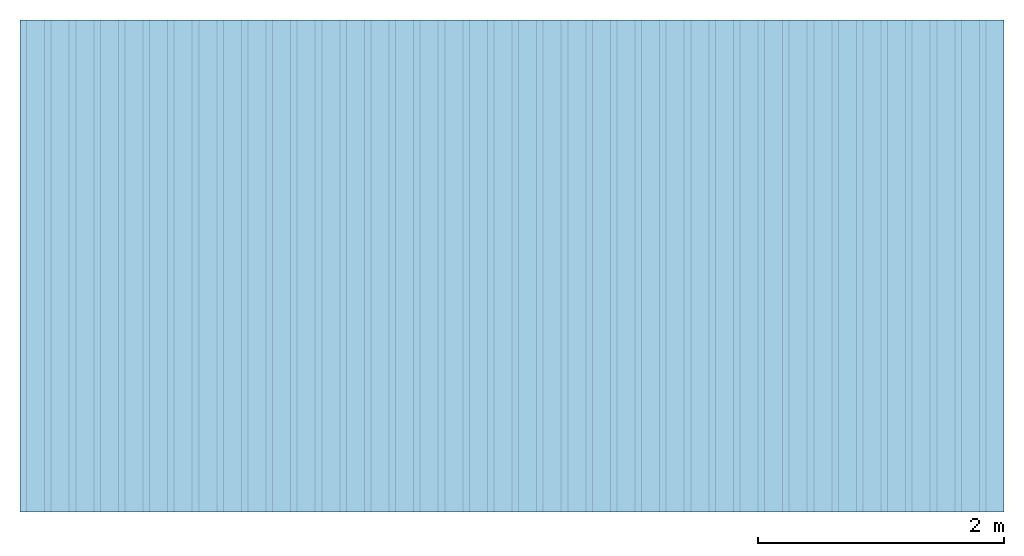
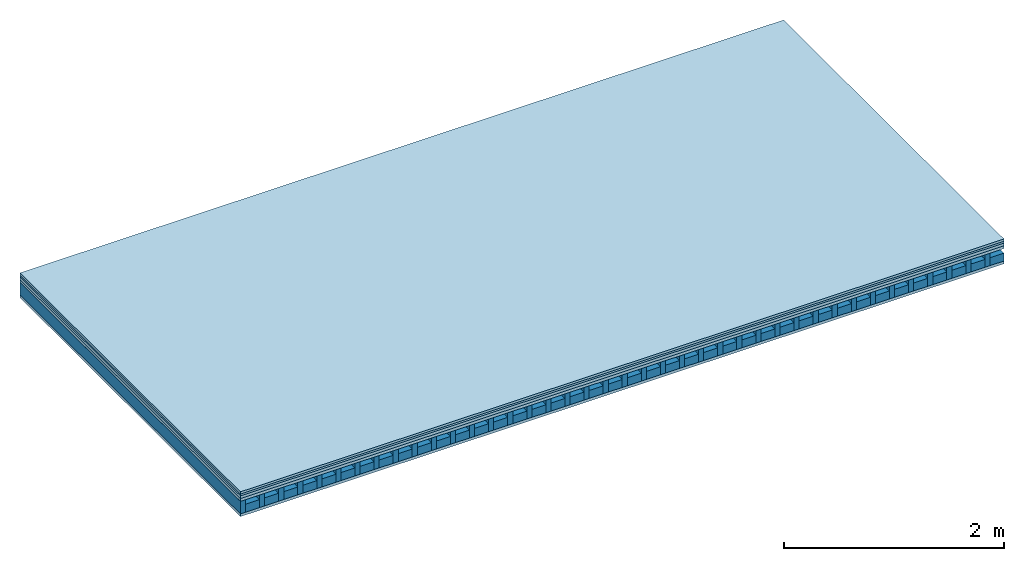
# One storey: 5 plates, 2 members, 1 element without a shape of its own.
"""IFC4 building model written with IfcOpenShell, lengths in metres."""

from ifc_helpers import new_model, si_unit, derived_unit, direction, frame, frame_2d, origin, origin_with_axes, place, context, project, spatial, rectangle, extrude, material, layer, layer_set, type_object, element, aggregate, save


model = new_model("IFC4")

# Units and contexts
plan_context = context("Plan", 3, precision=1e-05, world=origin(), true_north=direction((0.0, 1.0)))
model_context = context("Model", 3, precision=1e-05, world=origin(), true_north=direction((0.0, 1.0)))
ifc_project = project(units=[si_unit("LENGTHUNIT", "METRE"), derived_unit("SOUNDPRESSUREUNIT", [(si_unit("PRESSUREUNIT", "PASCAL", prefix="MICRO"), 0)]), si_unit("ENERGYUNIT", "JOULE", prefix="MEGA"), si_unit("MASSUNIT", "GRAM", prefix="KILO"), derived_unit("THERMALTRANSMITTANCEUNIT", [(si_unit("POWERUNIT", "WATT"), 1), (si_unit("AREAUNIT", "SQUARE_METRE"), -1), (si_unit("THERMODYNAMICTEMPERATUREUNIT", "KELVIN"), -1)]), derived_unit("AREADENSITYUNIT", [(si_unit("MASSUNIT", "GRAM", prefix="KILO"), 1), (si_unit("AREAUNIT", "SQUARE_METRE"), -1)]), derived_unit("USERDEFINED", [(si_unit("ENERGYUNIT", "JOULE", prefix="MEGA"), 1), (si_unit("AREAUNIT", "SQUARE_METRE"), -1)])], contexts=[plan_context, model_context])

# Site, building, storey
site = spatial("IfcSite", under=ifc_project)
building_placement = place(None, origin())
building = spatial("IfcBuilding", under=site, at=building_placement)
storey_placement = place(building_placement, origin())
storey = spatial("IfcBuildingStorey", under=building, at=storey_placement)

# Slab, members, plates
ifc_material_1 = material(Name="Floor heating system Therm38 longitudinal", Category="03.007")
ifc_layer_1 = layer(ifc_material_1, 0.025, Name="On-material")
ifc_material_2 = material(Name="32/30mm", Category="10.009")
ifc_layer_2 = layer(ifc_material_2, 0.02, Name="Impact sound insulation")
ifc_material_3 = material(Category="03.011")
ifc_layer_3 = layer(ifc_material_3, 0.03, Name="on Supporting structure")
ifc_material_4 = material(Name="box-element sheathing above")
ifc_layer_4 = layer(ifc_material_4, 0.031, Name="Sub-floor")
ifc_layer_5 = layer(None, 0.138, Name="Supporting structure")
ifc_material_5 = material(Name="box-element sheathing below")
ifc_layer_6 = layer(ifc_material_5, 0.031, Name="Lower layer 1")
ifc_layer_set = layer_set([ifc_layer_1, ifc_layer_2, ifc_layer_3, ifc_layer_4, ifc_layer_5, ifc_layer_6])
slab_type = type_object("IfcSlabType", Name="A1464", PredefinedType="NOTDEFINED", material=ifc_layer_set)
slab_placement = place(None, frame((0.0, 0.0, 0.0), z_axis=(0.0, 0.0, -1.0), x_axis=(1.0, 0.0, 0.0)))
slab = element("IfcSlab", 1, at=slab_placement, inside=storey, type_object=slab_type, material=ifc_layer_set, Name="Slab #1")
ifc_material_6 = material(Name="box-element LKE 12")
member_1_placement = place(slab_placement, origin())
member_1 = element("IfcMember", 2, at=member_1_placement, material=ifc_material_6, Name="Supporting structure", context=plan_context, shape_type="SweptSolid", body=[
    extrude(rectangle(XDim=0.054, YDim=0.138, at=frame_2d((0.027, 0.069), x_axis=(1.0, 0.0))), frame((0.0, 4.0, 0.106), z_axis=(0.0, -1.0, 0.0), x_axis=(1.0, 0.0, 0.0)), (0.0, 0.0, 1.0), 4.0),
    extrude(rectangle(XDim=0.054, YDim=0.138, at=frame_2d((0.027, 0.069), x_axis=(1.0, 0.0))), frame((0.2, 4.0, 0.106), z_axis=(0.0, -1.0, 0.0), x_axis=(1.0, 0.0, 0.0)), (0.0, 0.0, 1.0), 4.0),
    extrude(rectangle(XDim=0.054, YDim=0.138, at=frame_2d((0.027, 0.069), x_axis=(1.0, 0.0))), frame((0.4, 4.0, 0.106), z_axis=(0.0, -1.0, 0.0), x_axis=(1.0, 0.0, 0.0)), (0.0, 0.0, 1.0), 4.0),
    extrude(rectangle(XDim=0.054, YDim=0.138, at=frame_2d((0.027, 0.069), x_axis=(1.0, 0.0))), frame((0.6, 4.0, 0.106), z_axis=(0.0, -1.0, 0.0), x_axis=(1.0, 0.0, 0.0)), (0.0, 0.0, 1.0), 4.0),
    extrude(rectangle(XDim=0.054, YDim=0.138, at=frame_2d((0.027, 0.069), x_axis=(1.0, 0.0))), frame((0.8, 4.0, 0.106), z_axis=(0.0, -1.0, 0.0), x_axis=(1.0, 0.0, 0.0)), (0.0, 0.0, 1.0), 4.0),
    extrude(rectangle(XDim=0.054, YDim=0.138, at=frame_2d((0.027, 0.069), x_axis=(1.0, 0.0))), frame((1.0, 4.0, 0.106), z_axis=(0.0, -1.0, 0.0), x_axis=(1.0, 0.0, 0.0)), (0.0, 0.0, 1.0), 4.0),
    extrude(rectangle(XDim=0.054, YDim=0.138, at=frame_2d((0.027, 0.069), x_axis=(1.0, 0.0))), frame((1.2, 4.0, 0.106), z_axis=(0.0, -1.0, 0.0), x_axis=(1.0, 0.0, 0.0)), (0.0, 0.0, 1.0), 4.0),
    extrude(rectangle(XDim=0.054, YDim=0.138, at=frame_2d((0.027, 0.069), x_axis=(1.0, 0.0))), frame((1.4, 4.0, 0.106), z_axis=(0.0, -1.0, 0.0), x_axis=(1.0, 0.0, 0.0)), (0.0, 0.0, 1.0), 4.0),
    extrude(rectangle(XDim=0.054, YDim=0.138, at=frame_2d((0.027, 0.069), x_axis=(1.0, 0.0))), frame((1.6, 4.0, 0.106), z_axis=(0.0, -1.0, 0.0), x_axis=(1.0, 0.0, 0.0)), (0.0, 0.0, 1.0), 4.0),
    extrude(rectangle(XDim=0.054, YDim=0.138, at=frame_2d((0.027, 0.069), x_axis=(1.0, 0.0))), frame((1.8, 4.0, 0.106), z_axis=(0.0, -1.0, 0.0), x_axis=(1.0, 0.0, 0.0)), (0.0, 0.0, 1.0), 4.0),
    extrude(rectangle(XDim=0.054, YDim=0.138, at=frame_2d((0.027, 0.069), x_axis=(1.0, 0.0))), frame((2.0, 4.0, 0.106), z_axis=(0.0, -1.0, 0.0), x_axis=(1.0, 0.0, 0.0)), (0.0, 0.0, 1.0), 4.0),
    extrude(rectangle(XDim=0.054, YDim=0.138, at=frame_2d((0.027, 0.069), x_axis=(1.0, 0.0))), frame((2.2, 4.0, 0.106), z_axis=(0.0, -1.0, 0.0), x_axis=(1.0, 0.0, 0.0)), (0.0, 0.0, 1.0), 4.0),
    extrude(rectangle(XDim=0.054, YDim=0.138, at=frame_2d((0.027, 0.069), x_axis=(1.0, 0.0))), frame((2.4, 4.0, 0.106), z_axis=(0.0, -1.0, 0.0), x_axis=(1.0, 0.0, 0.0)), (0.0, 0.0, 1.0), 4.0),
    extrude(rectangle(XDim=0.054, YDim=0.138, at=frame_2d((0.027, 0.069), x_axis=(1.0, 0.0))), frame((2.6, 4.0, 0.106), z_axis=(0.0, -1.0, 0.0), x_axis=(1.0, 0.0, 0.0)), (0.0, 0.0, 1.0), 4.0),
    extrude(rectangle(XDim=0.054, YDim=0.138, at=frame_2d((0.027, 0.069), x_axis=(1.0, 0.0))), frame((2.8, 4.0, 0.106), z_axis=(0.0, -1.0, 0.0), x_axis=(1.0, 0.0, 0.0)), (0.0, 0.0, 1.0), 4.0),
    extrude(rectangle(XDim=0.054, YDim=0.138, at=frame_2d((0.027, 0.069), x_axis=(1.0, 0.0))), frame((3.0, 4.0, 0.106), z_axis=(0.0, -1.0, 0.0), x_axis=(1.0, 0.0, 0.0)), (0.0, 0.0, 1.0), 4.0),
    extrude(rectangle(XDim=0.054, YDim=0.138, at=frame_2d((0.027, 0.069), x_axis=(1.0, 0.0))), frame((3.2, 4.0, 0.106), z_axis=(0.0, -1.0, 0.0), x_axis=(1.0, 0.0, 0.0)), (0.0, 0.0, 1.0), 4.0),
    extrude(rectangle(XDim=0.054, YDim=0.138, at=frame_2d((0.027, 0.069), x_axis=(1.0, 0.0))), frame((3.4, 4.0, 0.106), z_axis=(0.0, -1.0, 0.0), x_axis=(1.0, 0.0, 0.0)), (0.0, 0.0, 1.0), 4.0),
    extrude(rectangle(XDim=0.054, YDim=0.138, at=frame_2d((0.027, 0.069), x_axis=(1.0, 0.0))), frame((3.6, 4.0, 0.106), z_axis=(0.0, -1.0, 0.0), x_axis=(1.0, 0.0, 0.0)), (0.0, 0.0, 1.0), 4.0),
    extrude(rectangle(XDim=0.054, YDim=0.138, at=frame_2d((0.027, 0.069), x_axis=(1.0, 0.0))), frame((3.8, 4.0, 0.106), z_axis=(0.0, -1.0, 0.0), x_axis=(1.0, 0.0, 0.0)), (0.0, 0.0, 1.0), 4.0),
    extrude(rectangle(XDim=0.054, YDim=0.138, at=frame_2d((0.027, 0.069), x_axis=(1.0, 0.0))), frame((4.0, 4.0, 0.106), z_axis=(0.0, -1.0, 0.0), x_axis=(1.0, 0.0, 0.0)), (0.0, 0.0, 1.0), 4.0),
    extrude(rectangle(XDim=0.054, YDim=0.138, at=frame_2d((0.027, 0.069), x_axis=(1.0, 0.0))), frame((4.2, 4.0, 0.106), z_axis=(0.0, -1.0, 0.0), x_axis=(1.0, 0.0, 0.0)), (0.0, 0.0, 1.0), 4.0),
    extrude(rectangle(XDim=0.054, YDim=0.138, at=frame_2d((0.027, 0.069), x_axis=(1.0, 0.0))), frame((4.4, 4.0, 0.106), z_axis=(0.0, -1.0, 0.0), x_axis=(1.0, 0.0, 0.0)), (0.0, 0.0, 1.0), 4.0),
    extrude(rectangle(XDim=0.054, YDim=0.138, at=frame_2d((0.027, 0.069), x_axis=(1.0, 0.0))), frame((4.6, 4.0, 0.106), z_axis=(0.0, -1.0, 0.0), x_axis=(1.0, 0.0, 0.0)), (0.0, 0.0, 1.0), 4.0),
    extrude(rectangle(XDim=0.054, YDim=0.138, at=frame_2d((0.027, 0.069), x_axis=(1.0, 0.0))), frame((4.8, 4.0, 0.106), z_axis=(0.0, -1.0, 0.0), x_axis=(1.0, 0.0, 0.0)), (0.0, 0.0, 1.0), 4.0),
    extrude(rectangle(XDim=0.054, YDim=0.138, at=frame_2d((0.027, 0.069), x_axis=(1.0, 0.0))), frame((5.0, 4.0, 0.106), z_axis=(0.0, -1.0, 0.0), x_axis=(1.0, 0.0, 0.0)), (0.0, 0.0, 1.0), 4.0),
    extrude(rectangle(XDim=0.054, YDim=0.138, at=frame_2d((0.027, 0.069), x_axis=(1.0, 0.0))), frame((5.2, 4.0, 0.106), z_axis=(0.0, -1.0, 0.0), x_axis=(1.0, 0.0, 0.0)), (0.0, 0.0, 1.0), 4.0),
    extrude(rectangle(XDim=0.054, YDim=0.138, at=frame_2d((0.027, 0.069), x_axis=(1.0, 0.0))), frame((5.4, 4.0, 0.106), z_axis=(0.0, -1.0, 0.0), x_axis=(1.0, 0.0, 0.0)), (0.0, 0.0, 1.0), 4.0),
    extrude(rectangle(XDim=0.054, YDim=0.138, at=frame_2d((0.027, 0.069), x_axis=(1.0, 0.0))), frame((5.6, 4.0, 0.106), z_axis=(0.0, -1.0, 0.0), x_axis=(1.0, 0.0, 0.0)), (0.0, 0.0, 1.0), 4.0),
    extrude(rectangle(XDim=0.054, YDim=0.138, at=frame_2d((0.027, 0.069), x_axis=(1.0, 0.0))), frame((5.8, 4.0, 0.106), z_axis=(0.0, -1.0, 0.0), x_axis=(1.0, 0.0, 0.0)), (0.0, 0.0, 1.0), 4.0),
    extrude(rectangle(XDim=0.054, YDim=0.138, at=frame_2d((0.027, 0.069), x_axis=(1.0, 0.0))), frame((6.0, 4.0, 0.106), z_axis=(0.0, -1.0, 0.0), x_axis=(1.0, 0.0, 0.0)), (0.0, 0.0, 1.0), 4.0),
    extrude(rectangle(XDim=0.054, YDim=0.138, at=frame_2d((0.027, 0.069), x_axis=(1.0, 0.0))), frame((6.2, 4.0, 0.106), z_axis=(0.0, -1.0, 0.0), x_axis=(1.0, 0.0, 0.0)), (0.0, 0.0, 1.0), 4.0),
    extrude(rectangle(XDim=0.054, YDim=0.138, at=frame_2d((0.027, 0.069), x_axis=(1.0, 0.0))), frame((6.4, 4.0, 0.106), z_axis=(0.0, -1.0, 0.0), x_axis=(1.0, 0.0, 0.0)), (0.0, 0.0, 1.0), 4.0),
    extrude(rectangle(XDim=0.054, YDim=0.138, at=frame_2d((0.027, 0.069), x_axis=(1.0, 0.0))), frame((6.6, 4.0, 0.106), z_axis=(0.0, -1.0, 0.0), x_axis=(1.0, 0.0, 0.0)), (0.0, 0.0, 1.0), 4.0),
    extrude(rectangle(XDim=0.054, YDim=0.138, at=frame_2d((0.027, 0.069), x_axis=(1.0, 0.0))), frame((6.8, 4.0, 0.106), z_axis=(0.0, -1.0, 0.0), x_axis=(1.0, 0.0, 0.0)), (0.0, 0.0, 1.0), 4.0),
    extrude(rectangle(XDim=0.054, YDim=0.138, at=frame_2d((0.027, 0.069), x_axis=(1.0, 0.0))), frame((7.0, 4.0, 0.106), z_axis=(0.0, -1.0, 0.0), x_axis=(1.0, 0.0, 0.0)), (0.0, 0.0, 1.0), 4.0),
    extrude(rectangle(XDim=0.054, YDim=0.138, at=frame_2d((0.027, 0.069), x_axis=(1.0, 0.0))), frame((7.2, 4.0, 0.106), z_axis=(0.0, -1.0, 0.0), x_axis=(1.0, 0.0, 0.0)), (0.0, 0.0, 1.0), 4.0),
    extrude(rectangle(XDim=0.054, YDim=0.138, at=frame_2d((0.027, 0.069), x_axis=(1.0, 0.0))), frame((7.4, 4.0, 0.106), z_axis=(0.0, -1.0, 0.0), x_axis=(1.0, 0.0, 0.0)), (0.0, 0.0, 1.0), 4.0),
    extrude(rectangle(XDim=0.054, YDim=0.138, at=frame_2d((0.027, 0.069), x_axis=(1.0, 0.0))), frame((7.6, 4.0, 0.106), z_axis=(0.0, -1.0, 0.0), x_axis=(1.0, 0.0, 0.0)), (0.0, 0.0, 1.0), 4.0),
    extrude(rectangle(XDim=0.054, YDim=0.138, at=frame_2d((0.027, 0.069), x_axis=(1.0, 0.0))), frame((7.8, 4.0, 0.106), z_axis=(0.0, -1.0, 0.0), x_axis=(1.0, 0.0, 0.0)), (0.0, 0.0, 1.0), 4.0),
])
ifc_material_7 = material(Name="Damper and limestone LKE 12")
member_2_placement = place(slab_placement, origin())
member_2 = element("IfcMember", 3, at=member_2_placement, material=ifc_material_7, Name="in supporting structure", context=plan_context, shape_type="SweptSolid", body=[
    extrude(rectangle(XDim=0.146, YDim=0.088, at=frame_2d((0.073, 0.044), x_axis=(1.0, 0.0))), frame((0.054, 4.0, 0.156), z_axis=(0.0, -1.0, 0.0), x_axis=(1.0, 0.0, 0.0)), (0.0, 0.0, 1.0), 4.0),
    extrude(rectangle(XDim=0.146, YDim=0.088, at=frame_2d((0.073, 0.044), x_axis=(1.0, 0.0))), frame((0.254, 4.0, 0.156), z_axis=(0.0, -1.0, 0.0), x_axis=(1.0, 0.0, 0.0)), (0.0, 0.0, 1.0), 4.0),
    extrude(rectangle(XDim=0.146, YDim=0.088, at=frame_2d((0.073, 0.044), x_axis=(1.0, 0.0))), frame((0.454, 4.0, 0.156), z_axis=(0.0, -1.0, 0.0), x_axis=(1.0, 0.0, 0.0)), (0.0, 0.0, 1.0), 4.0),
    extrude(rectangle(XDim=0.146, YDim=0.088, at=frame_2d((0.073, 0.044), x_axis=(1.0, 0.0))), frame((0.654, 4.0, 0.156), z_axis=(0.0, -1.0, 0.0), x_axis=(1.0, 0.0, 0.0)), (0.0, 0.0, 1.0), 4.0),
    extrude(rectangle(XDim=0.146, YDim=0.088, at=frame_2d((0.073, 0.044), x_axis=(1.0, 0.0))), frame((0.854, 4.0, 0.156), z_axis=(0.0, -1.0, 0.0), x_axis=(1.0, 0.0, 0.0)), (0.0, 0.0, 1.0), 4.0),
    extrude(rectangle(XDim=0.146, YDim=0.088, at=frame_2d((0.073, 0.044), x_axis=(1.0, 0.0))), frame((1.054, 4.0, 0.156), z_axis=(0.0, -1.0, 0.0), x_axis=(1.0, 0.0, 0.0)), (0.0, 0.0, 1.0), 4.0),
    extrude(rectangle(XDim=0.146, YDim=0.088, at=frame_2d((0.073, 0.044), x_axis=(1.0, 0.0))), frame((1.254, 4.0, 0.156), z_axis=(0.0, -1.0, 0.0), x_axis=(1.0, 0.0, 0.0)), (0.0, 0.0, 1.0), 4.0),
    extrude(rectangle(XDim=0.146, YDim=0.088, at=frame_2d((0.073, 0.044), x_axis=(1.0, 0.0))), frame((1.454, 4.0, 0.156), z_axis=(0.0, -1.0, 0.0), x_axis=(1.0, 0.0, 0.0)), (0.0, 0.0, 1.0), 4.0),
    extrude(rectangle(XDim=0.146, YDim=0.088, at=frame_2d((0.073, 0.044), x_axis=(1.0, 0.0))), frame((1.654, 4.0, 0.156), z_axis=(0.0, -1.0, 0.0), x_axis=(1.0, 0.0, 0.0)), (0.0, 0.0, 1.0), 4.0),
    extrude(rectangle(XDim=0.146, YDim=0.088, at=frame_2d((0.073, 0.044), x_axis=(1.0, 0.0))), frame((1.854, 4.0, 0.156), z_axis=(0.0, -1.0, 0.0), x_axis=(1.0, 0.0, 0.0)), (0.0, 0.0, 1.0), 4.0),
    extrude(rectangle(XDim=0.146, YDim=0.088, at=frame_2d((0.073, 0.044), x_axis=(1.0, 0.0))), frame((2.054, 4.0, 0.156), z_axis=(0.0, -1.0, 0.0), x_axis=(1.0, 0.0, 0.0)), (0.0, 0.0, 1.0), 4.0),
    extrude(rectangle(XDim=0.146, YDim=0.088, at=frame_2d((0.073, 0.044), x_axis=(1.0, 0.0))), frame((2.254, 4.0, 0.156), z_axis=(0.0, -1.0, 0.0), x_axis=(1.0, 0.0, 0.0)), (0.0, 0.0, 1.0), 4.0),
    extrude(rectangle(XDim=0.146, YDim=0.088, at=frame_2d((0.073, 0.044), x_axis=(1.0, 0.0))), frame((2.454, 4.0, 0.156), z_axis=(0.0, -1.0, 0.0), x_axis=(1.0, 0.0, 0.0)), (0.0, 0.0, 1.0), 4.0),
    extrude(rectangle(XDim=0.146, YDim=0.088, at=frame_2d((0.073, 0.044), x_axis=(1.0, 0.0))), frame((2.654, 4.0, 0.156), z_axis=(0.0, -1.0, 0.0), x_axis=(1.0, 0.0, 0.0)), (0.0, 0.0, 1.0), 4.0),
    extrude(rectangle(XDim=0.146, YDim=0.088, at=frame_2d((0.073, 0.044), x_axis=(1.0, 0.0))), frame((2.854, 4.0, 0.156), z_axis=(0.0, -1.0, 0.0), x_axis=(1.0, 0.0, 0.0)), (0.0, 0.0, 1.0), 4.0),
    extrude(rectangle(XDim=0.146, YDim=0.088, at=frame_2d((0.073, 0.044), x_axis=(1.0, 0.0))), frame((3.054, 4.0, 0.156), z_axis=(0.0, -1.0, 0.0), x_axis=(1.0, 0.0, 0.0)), (0.0, 0.0, 1.0), 4.0),
    extrude(rectangle(XDim=0.146, YDim=0.088, at=frame_2d((0.073, 0.044), x_axis=(1.0, 0.0))), frame((3.254, 4.0, 0.156), z_axis=(0.0, -1.0, 0.0), x_axis=(1.0, 0.0, 0.0)), (0.0, 0.0, 1.0), 4.0),
    extrude(rectangle(XDim=0.146, YDim=0.088, at=frame_2d((0.073, 0.044), x_axis=(1.0, 0.0))), frame((3.454, 4.0, 0.156), z_axis=(0.0, -1.0, 0.0), x_axis=(1.0, 0.0, 0.0)), (0.0, 0.0, 1.0), 4.0),
    extrude(rectangle(XDim=0.146, YDim=0.088, at=frame_2d((0.073, 0.044), x_axis=(1.0, 0.0))), frame((3.654, 4.0, 0.156), z_axis=(0.0, -1.0, 0.0), x_axis=(1.0, 0.0, 0.0)), (0.0, 0.0, 1.0), 4.0),
    extrude(rectangle(XDim=0.146, YDim=0.088, at=frame_2d((0.073, 0.044), x_axis=(1.0, 0.0))), frame((3.854, 4.0, 0.156), z_axis=(0.0, -1.0, 0.0), x_axis=(1.0, 0.0, 0.0)), (0.0, 0.0, 1.0), 4.0),
    extrude(rectangle(XDim=0.146, YDim=0.088, at=frame_2d((0.073, 0.044), x_axis=(1.0, 0.0))), frame((4.054, 4.0, 0.156), z_axis=(0.0, -1.0, 0.0), x_axis=(1.0, 0.0, 0.0)), (0.0, 0.0, 1.0), 4.0),
    extrude(rectangle(XDim=0.146, YDim=0.088, at=frame_2d((0.073, 0.044), x_axis=(1.0, 0.0))), frame((4.254, 4.0, 0.156), z_axis=(0.0, -1.0, 0.0), x_axis=(1.0, 0.0, 0.0)), (0.0, 0.0, 1.0), 4.0),
    extrude(rectangle(XDim=0.146, YDim=0.088, at=frame_2d((0.073, 0.044), x_axis=(1.0, 0.0))), frame((4.454, 4.0, 0.156), z_axis=(0.0, -1.0, 0.0), x_axis=(1.0, 0.0, 0.0)), (0.0, 0.0, 1.0), 4.0),
    extrude(rectangle(XDim=0.146, YDim=0.088, at=frame_2d((0.073, 0.044), x_axis=(1.0, 0.0))), frame((4.654, 4.0, 0.156), z_axis=(0.0, -1.0, 0.0), x_axis=(1.0, 0.0, 0.0)), (0.0, 0.0, 1.0), 4.0),
    extrude(rectangle(XDim=0.146, YDim=0.088, at=frame_2d((0.073, 0.044), x_axis=(1.0, 0.0))), frame((4.854, 4.0, 0.156), z_axis=(0.0, -1.0, 0.0), x_axis=(1.0, 0.0, 0.0)), (0.0, 0.0, 1.0), 4.0),
    extrude(rectangle(XDim=0.146, YDim=0.088, at=frame_2d((0.073, 0.044), x_axis=(1.0, 0.0))), frame((5.054, 4.0, 0.156), z_axis=(0.0, -1.0, 0.0), x_axis=(1.0, 0.0, 0.0)), (0.0, 0.0, 1.0), 4.0),
    extrude(rectangle(XDim=0.146, YDim=0.088, at=frame_2d((0.073, 0.044), x_axis=(1.0, 0.0))), frame((5.254, 4.0, 0.156), z_axis=(0.0, -1.0, 0.0), x_axis=(1.0, 0.0, 0.0)), (0.0, 0.0, 1.0), 4.0),
    extrude(rectangle(XDim=0.146, YDim=0.088, at=frame_2d((0.073, 0.044), x_axis=(1.0, 0.0))), frame((5.454, 4.0, 0.156), z_axis=(0.0, -1.0, 0.0), x_axis=(1.0, 0.0, 0.0)), (0.0, 0.0, 1.0), 4.0),
    extrude(rectangle(XDim=0.146, YDim=0.088, at=frame_2d((0.073, 0.044), x_axis=(1.0, 0.0))), frame((5.654, 4.0, 0.156), z_axis=(0.0, -1.0, 0.0), x_axis=(1.0, 0.0, 0.0)), (0.0, 0.0, 1.0), 4.0),
    extrude(rectangle(XDim=0.146, YDim=0.088, at=frame_2d((0.073, 0.044), x_axis=(1.0, 0.0))), frame((5.854, 4.0, 0.156), z_axis=(0.0, -1.0, 0.0), x_axis=(1.0, 0.0, 0.0)), (0.0, 0.0, 1.0), 4.0),
    extrude(rectangle(XDim=0.146, YDim=0.088, at=frame_2d((0.073, 0.044), x_axis=(1.0, 0.0))), frame((6.054, 4.0, 0.156), z_axis=(0.0, -1.0, 0.0), x_axis=(1.0, 0.0, 0.0)), (0.0, 0.0, 1.0), 4.0),
    extrude(rectangle(XDim=0.146, YDim=0.088, at=frame_2d((0.073, 0.044), x_axis=(1.0, 0.0))), frame((6.254, 4.0, 0.156), z_axis=(0.0, -1.0, 0.0), x_axis=(1.0, 0.0, 0.0)), (0.0, 0.0, 1.0), 4.0),
    extrude(rectangle(XDim=0.146, YDim=0.088, at=frame_2d((0.073, 0.044), x_axis=(1.0, 0.0))), frame((6.454, 4.0, 0.156), z_axis=(0.0, -1.0, 0.0), x_axis=(1.0, 0.0, 0.0)), (0.0, 0.0, 1.0), 4.0),
    extrude(rectangle(XDim=0.146, YDim=0.088, at=frame_2d((0.073, 0.044), x_axis=(1.0, 0.0))), frame((6.654, 4.0, 0.156), z_axis=(0.0, -1.0, 0.0), x_axis=(1.0, 0.0, 0.0)), (0.0, 0.0, 1.0), 4.0),
    extrude(rectangle(XDim=0.146, YDim=0.088, at=frame_2d((0.073, 0.044), x_axis=(1.0, 0.0))), frame((6.854, 4.0, 0.156), z_axis=(0.0, -1.0, 0.0), x_axis=(1.0, 0.0, 0.0)), (0.0, 0.0, 1.0), 4.0),
    extrude(rectangle(XDim=0.146, YDim=0.088, at=frame_2d((0.073, 0.044), x_axis=(1.0, 0.0))), frame((7.054, 4.0, 0.156), z_axis=(0.0, -1.0, 0.0), x_axis=(1.0, 0.0, 0.0)), (0.0, 0.0, 1.0), 4.0),
    extrude(rectangle(XDim=0.146, YDim=0.088, at=frame_2d((0.073, 0.044), x_axis=(1.0, 0.0))), frame((7.254, 4.0, 0.156), z_axis=(0.0, -1.0, 0.0), x_axis=(1.0, 0.0, 0.0)), (0.0, 0.0, 1.0), 4.0),
    extrude(rectangle(XDim=0.146, YDim=0.088, at=frame_2d((0.073, 0.044), x_axis=(1.0, 0.0))), frame((7.454, 4.0, 0.156), z_axis=(0.0, -1.0, 0.0), x_axis=(1.0, 0.0, 0.0)), (0.0, 0.0, 1.0), 4.0),
    extrude(rectangle(XDim=0.146, YDim=0.088, at=frame_2d((0.073, 0.044), x_axis=(1.0, 0.0))), frame((7.654, 4.0, 0.156), z_axis=(0.0, -1.0, 0.0), x_axis=(1.0, 0.0, 0.0)), (0.0, 0.0, 1.0), 4.0),
    extrude(rectangle(XDim=0.146, YDim=0.088, at=frame_2d((0.073, 0.044), x_axis=(1.0, 0.0))), frame((7.854, 4.0, 0.156), z_axis=(0.0, -1.0, 0.0), x_axis=(1.0, 0.0, 0.0)), (0.0, 0.0, 1.0), 4.0),
])
plate_1_placement = place(slab_placement, origin())
plate_1 = element("IfcPlate", 4, at=plate_1_placement, material=ifc_material_1, Name="On-material", context=plan_context, shape_type="SweptSolid", body=[
    extrude(rectangle(XDim=8.0, YDim=4.0, at=frame_2d((4.0, 2.0), x_axis=(1.0, 0.0))), origin_with_axes(), (0.0, 0.0, 1.0), 0.025),
])
plate_2_placement = place(slab_placement, origin())
plate_2 = element("IfcPlate", 5, at=plate_2_placement, material=ifc_material_2, Name="Impact sound insulation", context=plan_context, shape_type="SweptSolid", body=[
    extrude(rectangle(XDim=8.0, YDim=4.0, at=frame_2d((4.0, 2.0), x_axis=(1.0, 0.0))), frame((0.0, 0.0, 0.025), z_axis=(0.0, 0.0, 1.0), x_axis=(1.0, 0.0, 0.0)), (0.0, 0.0, 1.0), 0.02),
])
plate_3_placement = place(slab_placement, origin())
plate_3 = element("IfcPlate", 6, at=plate_3_placement, material=ifc_material_3, Name="on Supporting structure", context=plan_context, shape_type="SweptSolid", body=[
    extrude(rectangle(XDim=8.0, YDim=4.0, at=frame_2d((4.0, 2.0), x_axis=(1.0, 0.0))), frame((0.0, 0.0, 0.045), z_axis=(0.0, 0.0, 1.0), x_axis=(1.0, 0.0, 0.0)), (0.0, 0.0, 1.0), 0.03),
])
plate_4_placement = place(slab_placement, origin())
plate_4 = element("IfcPlate", 7, at=plate_4_placement, material=ifc_material_4, Name="Sub-floor", context=plan_context, shape_type="SweptSolid", body=[
    extrude(rectangle(XDim=8.0, YDim=4.0, at=frame_2d((4.0, 2.0), x_axis=(1.0, 0.0))), frame((0.0, 0.0, 0.075), z_axis=(0.0, 0.0, 1.0), x_axis=(1.0, 0.0, 0.0)), (0.0, 0.0, 1.0), 0.031),
])
plate_5_placement = place(slab_placement, origin())
plate_5 = element("IfcPlate", 8, at=plate_5_placement, material=ifc_material_5, Name="Lower layer 1", context=plan_context, shape_type="SweptSolid", body=[
    extrude(rectangle(XDim=8.0, YDim=4.0, at=frame_2d((4.0, 2.0), x_axis=(1.0, 0.0))), frame((0.0, 0.0, 0.244), z_axis=(0.0, 0.0, 1.0), x_axis=(1.0, 0.0, 0.0)), (0.0, 0.0, 1.0), 0.031),
])
aggregate(slab, [plate_1, plate_2, plate_3, plate_4, member_1, member_2, plate_5])

save(model, "model.ifc")
